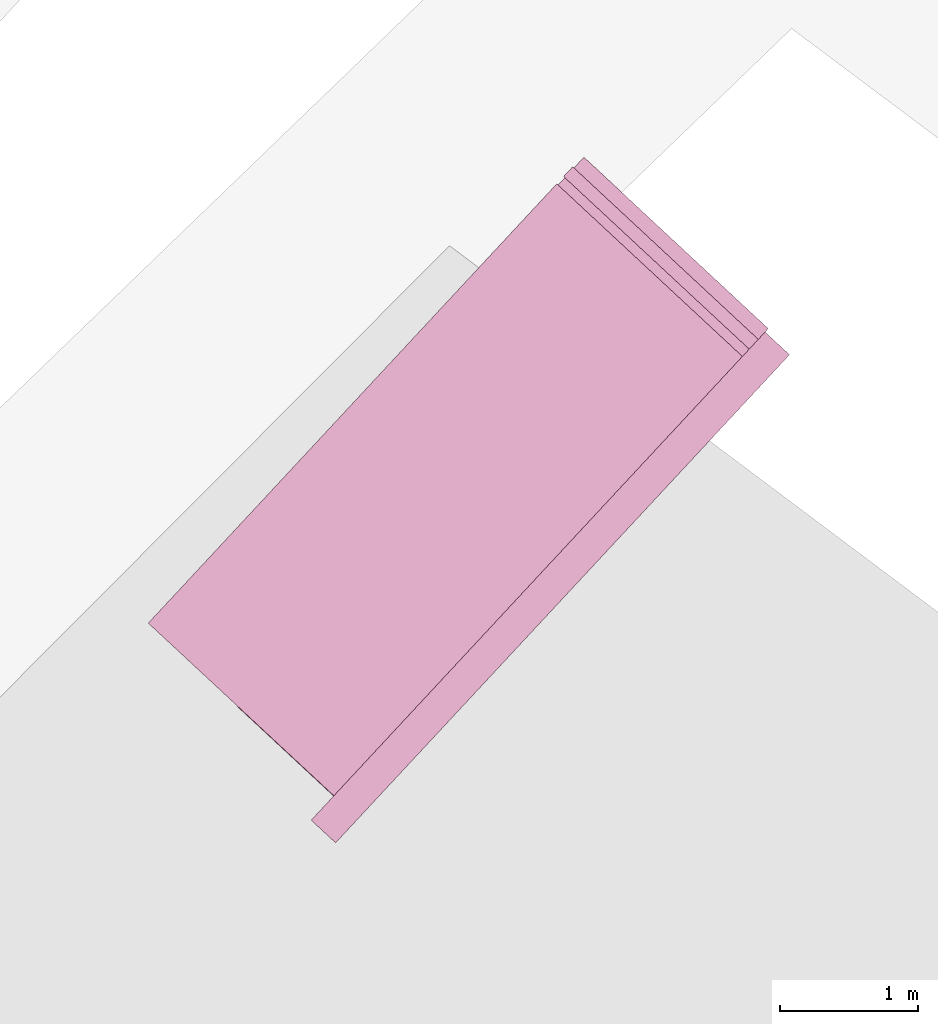
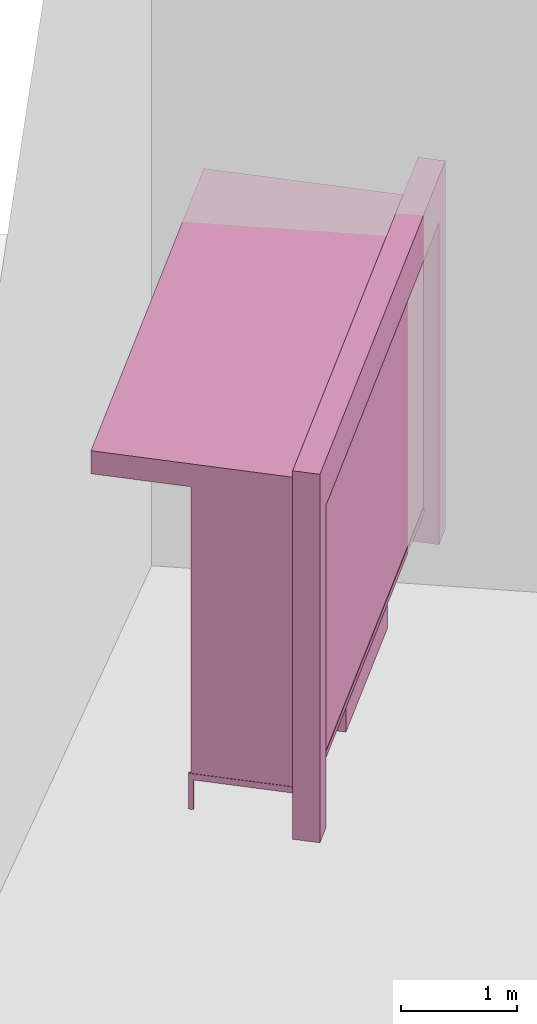
# One storey, part 38 of 200: 1 furnishing.
"""IFC4 building model written with IfcOpenShell, lengths in metres."""

from ifc_helpers import new_model, si_unit, origin_with_axes, place, context, subcontext, project, spatial, triangles, material, element, save


model = new_model("IFC4")

# Units and contexts
model_context = context("Model", 3, precision=1e-05, world=origin_with_axes())
body_context = subcontext(model_context, "Body", "Model", "MODEL_VIEW")
ifc_project = project(units=[si_unit("VOLUMEUNIT", "CUBIC_METRE"), si_unit("LENGTHUNIT", "METRE"), si_unit("AREAUNIT", "SQUARE_METRE")], contexts=[model_context])

# Site, building, storey
site_placement = place(None, origin_with_axes())
site = spatial("IfcSite", under=ifc_project, at=site_placement)
building_placement = place(site_placement, origin_with_axes())
building = spatial("IfcBuilding", under=site, at=building_placement, Name="Building")
storey_placement = place(building_placement, origin_with_axes())
storey = spatial("IfcBuildingStorey", under=building, at=storey_placement, Name="Ground")

# Furnishing
ifc_material = material(Name="busStop")
furnishing_placement = place(storey_placement, origin_with_axes())
element("IfcFurnishingElement", 1, at=furnishing_placement, inside=storey, material=ifc_material, Name="cw_instances_busStop_28", context=body_context, shape_type="Tessellation", body=[
    triangles([(673.4360777471168, -592.662081831775, 3.3828914363241944), (672.0004949629046, -597.2523688925979, 3.3828914363241944), (674.9553393168015, -594.0749006714976, 3.3828914363241944), (670.4812331198481, -595.8395500400575, 3.3828914363241944), (673.4360776765063, -592.6620817661119, 3.6239502858274126), (672.0004948922941, -597.2523688269347, 3.6239502858274126), (670.4812330492376, -595.8395499743943, 3.6239502858274126), (674.9553392461911, -594.0749006058344, 3.6239502858274126), (673.4360777471168, -592.662081831775, 3.3828914363241944), (670.4812330492376, -595.8395499743943, 3.6239502858274126), (670.4812331198481, -595.8395500400575, 3.3828914363241944), (673.4360776765063, -592.6620817661119, 3.6239502858274126), (670.4812331198481, -595.8395500400575, 3.3828914363241944), (672.0004948922941, -597.2523688269347, 3.6239502858274126), (672.0004949629046, -597.2523688925979, 3.3828914363241944), (670.4812330492376, -595.8395499743943, 3.6239502858274126), (672.0004949629046, -597.2523688925979, 3.3828914363241944), (674.9553392461911, -594.0749006058344, 3.6239502858274126), (674.9553393168015, -594.0749006714976, 3.3828914363241944), (672.0004948922941, -597.2523688269347, 3.6239502858274126), (674.9553393168015, -594.0749006714976, 3.3828914363241944), (673.4360776765063, -592.6620817661119, 3.6239502858274126), (673.4360777471168, -592.662081831775, 3.3828914363241944), (674.9553392461911, -594.0749006058344, 3.6239502858274126), (674.7788129463231, -593.9107423906706, 3.8650087335661496), (675.1194970702991, -593.89837418371, 3.8650087335661496), (674.9553389755177, -594.0749003541255, 3.8650087335661496), (674.9429710411044, -593.734216220255, 3.8650087335661496), (674.7788129463231, -593.9107423906706, 3.6239502858274126), (674.9429710411044, -593.734216220255, 3.8650087335661496), (674.7788129463231, -593.9107423906706, 3.8650087335661496), (674.9429710411044, -593.734216220255, 3.6239502858274126), (671.6598104869258, -597.2647364869268, 3.6239502858274126), (671.8363366573413, -597.4288945817083, 3.8650087335661496), (671.8363366573413, -597.4288945817083, 3.6239502858274126), (671.6598104869258, -597.2647364869268, 3.8650087335661496), (672.0004946098525, -597.2523685642819, 3.6239502858274126), (671.8363366573413, -597.4288945817083, 3.8650087335661496), (672.0004946098525, -597.2523685642819, 3.8650087335661496), (671.8363366573413, -597.4288945817083, 3.6239502858274126), (675.1194971997515, -593.8983743040925, 3.6239502858274126), (674.9429710411044, -593.734216220255, 3.8650087335661496), (674.9429710411044, -593.734216220255, 3.6239502858274126), (675.1194970702991, -593.89837418371, 3.8650087335661496), (671.8239685806577, -597.088210600827, 3.8650087335661496), (672.0004946098525, -597.2523685642819, 3.8650087335661496), (671.8239685806577, -597.088210600827, 3.6239502858274126), (671.8239685806577, -597.088210600827, 3.8650087335661496), (675.1194971997515, -593.8983743040925, 3.6239502858274126), (674.9553389755177, -594.0749003541255, 3.8650087335661496), (675.1194970702991, -593.89837418371, 3.8650087335661496), (674.9553389755177, -594.0749003541255, 3.6239502858274126), (671.6598104869258, -597.2647364869268, 3.8650087335661496), (671.8363366573413, -597.4288945817083, 3.8650087335661496), (671.6598104869258, -597.2647364869268, 3.6239502858274126), (671.6598104869258, -597.2647364869268, 3.8650087335661496), (675.1194978352454, -593.8983748950612, 9.481641759365404e-07), (674.9429718766611, -593.7342169972695, 8.999524381770554e-07), (674.9553397404641, -594.0749010654768, 9.481641759365404e-07), (675.1194978352454, -593.8983748950612, 9.481641759365404e-07), (674.9553389755177, -594.0749003541255, 3.6239502858274126), (674.7788136524273, -593.9107430473025, 8.999524381770554e-07), (674.7788129463231, -593.9107423906706, 3.6239502858274126), (674.9553397404641, -594.0749010654768, 9.481641759365404e-07), (674.9429718766611, -593.7342169972695, 8.999524381770554e-07), (674.7788136524273, -593.9107430473025, 8.999524381770554e-07), (671.6598123739182, -597.2647361568869, 8.999524381770554e-07), (671.8363374222876, -597.4288952930594, 9.481641759365404e-07), (671.8239703373731, -597.0882101276922, 8.999524381770554e-07), (671.6598123739182, -597.2647361568869, 8.999524381770554e-07), (671.8239685806577, -597.088210600827, 3.6239502858274126), (672.0004964254098, -597.2523681458665, 9.481641759365404e-07), (672.0004946098525, -597.2523685642819, 3.6239502858274126), (671.8239703373731, -597.0882101276922, 8.999524381770554e-07), (671.8363374222876, -597.4288952930594, 9.481641759365404e-07), (672.0004964254098, -597.2523681458665, 9.481641759365404e-07), (671.1273741282491, -596.4400799329549, 0.3460205594970761), (671.8936109857975, -597.1526314055794, 3.3828914363241944), (671.8936116212913, -597.1526319965482, 0.34602073627344787), (671.1273735515974, -596.4400793967054, 3.3828914363241944), (671.904555476037, -597.1408636048011, 0.34602073627344787), (671.138317406343, -596.4283110049583, 3.3828914363241944), (671.1383179829949, -596.4283115412078, 0.3460205594970761), (671.9045548405431, -597.1408630138324, 3.3828914363241944), (671.1383179829949, -596.4283115412078, 0.3460205594970761), (671.1273735515974, -596.4400793967054, 3.3828914363241944), (671.1273741282491, -596.4400799329549, 0.3460205594970761), (671.138317406343, -596.4283110049583, 3.3828914363241944), (671.9072915081225, -597.1379214333118, 0.31387960990828295), (671.1246382627952, -596.4430219960549, 0.31387941706133193), (671.8908757205321, -597.1555740268166, 0.31387960990828295), (671.1410540503856, -596.4253694025501, 0.31387941706133193), (671.9072915081225, -597.1379214333118, 0.37816187870919205), (671.1246382510268, -596.4430219851109, 0.378161685862241), (671.1410540386172, -596.4253693916062, 0.378161685862241), (671.8908757205321, -597.1555740268166, 0.37816187870919205), (671.9072915081225, -597.1379214333118, 0.31387960990828295), (671.1410540386172, -596.4253693916062, 0.378161685862241), (671.1410540503856, -596.4253694025501, 0.31387941706133193), (671.9072915081225, -597.1379214333118, 0.37816187870919205), (671.1246382627952, -596.4430219960549, 0.31387941706133193), (671.8908757205321, -597.1555740268166, 0.37816187870919205), (671.8908757205321, -597.1555740268166, 0.31387960990828295), (671.1246382510268, -596.4430219851109, 0.378161685862241), (671.1246382510268, -596.4430219851109, 0.378161685862241), (671.1410540503856, -596.4253694025501, 0.31387941706133193), (671.1410540386172, -596.4253693916062, 0.378161685862241), (671.1246382627952, -596.4430219960549, 0.31387941706133193), (671.1223077074548, -596.4130321553358, 0.378161685862241), (671.1433856590356, -596.4553578746113, 0.378161685862241), (671.1109753345332, -596.425218337176, 0.378161685862241), (671.1547180319571, -596.4431716927711, 0.378161685862241), (671.1223078957493, -596.4130323304377, 1.446352132784553e-07), (671.1109753345332, -596.425218337176, 0.378161685862241), (671.1109755228277, -596.4252185122779, 1.446352132784553e-07), (671.1223077074548, -596.4130321553358, 0.378161685862241), (671.1109755228277, -596.4252185122779, 1.446352132784553e-07), (671.1433856590356, -596.4553578746113, 0.378161685862241), (671.1433857414145, -596.4553579512184, 1.60705792531617e-07), (671.1109753345332, -596.425218337176, 0.378161685862241), (671.1433857414145, -596.4553579512184, 1.60705792531617e-07), (671.1547180319571, -596.4431716927711, 0.378161685862241), (671.154718114336, -596.4431717693782, 1.60705792531617e-07), (671.1433856590356, -596.4553578746113, 0.378161685862241), (671.154718114336, -596.4431717693782, 1.60705792531617e-07), (671.1223077074548, -596.4130321553358, 0.378161685862241), (671.1223078957493, -596.4130323304377, 1.446352132784553e-07), (671.1547180319571, -596.4431716927711, 0.378161685862241), (673.8407760131898, -594.822775131854, 1.124940901274063), (672.8587585035449, -596.1041115512872, 1.1249409976975384), (672.7463890911865, -595.9996151550814, 1.124940901274063), (673.9531452843273, -594.9272713967334, 1.1249409976975384), (672.7463892324074, -595.9996152864078, 4.981879568480127e-07), (673.8407760131898, -594.822775131854, 0.9642351730247629), (672.7463890911865, -595.9996151550814, 0.9642351730247629), (673.8407762603263, -594.8227753616751, 4.981879568480127e-07), (672.8587587859865, -596.10411181394, 5.303291153543362e-07), (672.7463890911865, -595.9996151550814, 0.9642351730247629), (672.8587585035449, -596.1041115512872, 0.9642352694482383), (672.7463892324074, -595.9996152864078, 4.981879568480127e-07), (673.9531455667691, -594.9272716593862, 5.303291153543362e-07), (672.8587585035449, -596.1041115512872, 0.9642352694482383), (673.9531452843273, -594.9272713967334, 0.9642352694482383), (672.8587587859865, -596.10411181394, 5.303291153543362e-07), (673.8407762603263, -594.8227753616751, 4.981879568480127e-07), (673.9531452843273, -594.9272713967334, 0.9642352694482383), (673.8407760131898, -594.822775131854, 0.9642351730247629), (673.9531455667691, -594.9272716593862, 5.303291153543362e-07), (672.2756529976427, -595.5618605712764, 1.1249408048505873), (673.370039860804, -594.3850204933296, 0.9642350766012873), (673.3700398372672, -594.3850204714419, 1.1249408048505873), (672.2756530094111, -595.5618605822202, 0.9642350766012873), (672.8587585035449, -596.1041115512872, 1.1249409976975384), (672.7463890911865, -595.9996151550814, 1.124940901274063), (673.9531452843273, -594.9272713967334, 1.1249409976975384), (672.8587585035449, -596.1041115512872, 1.1249409976975384), (673.8407760131898, -594.822775131854, 1.124940901274063), (673.9531452843273, -594.9272713967334, 1.1249409976975384), (673.3700398372672, -594.3850204714419, 1.1249408048505873), (672.2756529976427, -595.5618605712764, 1.1249408048505873), (673.370039860804, -594.3850204933296, 0.9642350766012873), (673.3700398372672, -594.3850204714419, 1.1249408048505873), (672.2756529976427, -595.5618605712764, 1.1249408048505873), (672.2756530094111, -595.5618605822202, 0.9642350766012873), (674.9375242709053, -593.8675855550316, 0.34602073627344787), (671.8054770410532, -597.2356059961706, 3.503420861075804), (671.8054777353891, -597.2356066418588, 0.34602073627344787), (674.9375237766325, -593.8675850953892, 3.503420861075804), (671.8172461389045, -597.2465505075482, 0.34602073627344787), (674.9492921683794, -593.8785289501349, 3.503420861075804), (674.9492926626524, -593.8785294097772, 0.34602073627344787), (671.8172454328003, -597.2465498509164, 3.503420861075804), (674.8844663400779, -593.6555367651829, 0.5810437654796049), (673.6919274325179, -592.5465515390442, 3.219596834180686), (673.6919278561804, -592.5465519330234, 0.5810434762091784), (674.8844658928786, -593.655536349316, 3.219596834180686), (674.9660206159161, -593.7094315675729, 0.4846202738900554), (673.702871710926, -592.5347835412763, 0.5810434762091784), (673.6322624001111, -592.4691192948042, 0.48461995247847034), (674.8954101948235, -593.6437683734358, 0.5810437654796049), (673.7028712872635, -592.5347831472972, 3.219596834180686), (673.63226072495, -592.4691198218337, 3.3160202132761807), (674.8954097476242, -593.6437679575689, 3.219596834180686), (674.9660201334116, -593.7094311188744, 3.3160202132761807), (674.8954101948235, -593.6437683734358, 0.5810437654796049), (673.6919278561804, -592.5465519330234, 0.5810434762091784), (673.702871710926, -592.5347835412763, 0.5810434762091784), (674.8844663400779, -593.6555367651829, 0.5810437654796049), (673.702871710926, -592.5347835412763, 0.5810434762091784), (673.6919274325179, -592.5465515390442, 3.219596834180686), (673.7028712872635, -592.5347831472972, 3.219596834180686), (673.6919278561804, -592.5465519330234, 0.5810434762091784), (673.7028712872635, -592.5347831472972, 3.219596834180686), (674.8844658928786, -593.655536349316, 3.219596834180686), (674.8954097476242, -593.6437679575689, 3.219596834180686), (673.6919274325179, -592.5465515390442, 3.219596834180686), (674.8954097476242, -593.6437679575689, 3.219596834180686), (674.8844663400779, -593.6555367651829, 0.5810437654796049), (674.8954101948235, -593.6437683734358, 0.5810437654796049), (674.8844658928786, -593.655536349316, 3.219596834180686), (673.4220050104377, -592.6952167203161, 3.3160202132761807), (674.9660201334116, -593.7094311188744, 3.3160202132761807), (674.7557642070681, -593.9355278203672, 3.3160202132761807), (673.63226072495, -592.4691198218337, 3.3160202132761807), (673.4220056459316, -592.6952173112849, 0.48461995247847034), (673.63226072495, -592.4691198218337, 3.3160202132761807), (673.4220050104377, -592.6952167203161, 3.3160202132761807), (673.6322624001111, -592.4691192948042, 0.48461995247847034), (674.9660206159161, -593.7094315675729, 0.4846202738900554), (674.7557642070681, -593.9355278203672, 3.3160202132761807), (674.9660201334116, -593.7094311188744, 3.3160202132761807), (674.7557647719514, -593.9355283456728, 0.4846202738900554), (674.6960982291413, -593.8580967816764, 0.5810437654796049), (673.5035594274968, -592.7491116540325, 3.219596834180686), (674.6960976407211, -593.8580962344831, 3.219596834180686), (673.5035598511594, -592.7491120480117, 0.5810434762091784), (674.7557647719514, -593.9355283456728, 0.4846202738900554), (673.4926159964137, -592.7608804397588, 0.5810434762091784), (674.6851543743956, -593.8698651734235, 0.5810437654796049), (673.4220056459316, -592.6952173112849, 0.48461995247847034), (673.4926155727512, -592.7608800457796, 3.219596834180686), (673.4220050104377, -592.6952167203161, 3.3160202132761807), (674.6851537859754, -593.8698646262302, 3.219596834180686), (674.7557642070681, -593.9355278203672, 3.3160202132761807), (674.6851543743956, -593.8698651734235, 0.5810437654796049), (673.5035598511594, -592.7491120480117, 0.5810434762091784), (674.6960982291413, -593.8580967816764, 0.5810437654796049), (673.4926159964137, -592.7608804397588, 0.5810434762091784), (673.4926159964137, -592.7608804397588, 0.5810434762091784), (673.5035594274968, -592.7491116540325, 3.219596834180686), (673.5035598511594, -592.7491120480117, 0.5810434762091784), (673.4926155727512, -592.7608800457796, 3.219596834180686), (673.4926155727512, -592.7608800457796, 3.219596834180686), (674.6960976407211, -593.8580962344831, 3.219596834180686), (673.5035594274968, -592.7491116540325, 3.219596834180686), (674.6851537859754, -593.8698646262302, 3.219596834180686), (674.6851537859754, -593.8698646262302, 3.219596834180686), (674.6960982291413, -593.8580967816764, 0.5810437654796049), (674.6960976407211, -593.8580962344831, 3.219596834180686), (674.6851543743956, -593.8698651734235, 0.5810437654796049), (673.5509871877508, -592.5385148305454, 3.3290117659679117), (674.8280607119185, -593.8577847433567, 3.3290117659679117), (673.4853250989441, -592.6091240630292, 3.3290117659679117), (674.8937238403923, -593.7871743928745, 3.3290117659679117), (673.5509888530173, -592.5385140309686, 0.0), (673.4853250989441, -592.6091240630292, 3.3290117659679117), (673.4853255932171, -592.6091245226716, 0.0), (673.5509871877508, -592.5385148305454, 3.3290117659679117), (673.4853255932171, -592.6091245226716, 0.0), (674.8280607119185, -593.8577847433567, 3.3290117659679117), (674.8280612650335, -593.8577852577183, 5.142585361011745e-07), (673.4853250989441, -592.6091240630292, 3.3290117659679117), (674.8280612650335, -593.8577852577183, 5.142585361011745e-07), (674.8937238403923, -593.7871743928745, 3.3290117659679117), (674.8937243935073, -593.7871749072361, 5.142585361011745e-07), (674.8280607119185, -593.8577847433567, 3.3290117659679117), (674.8937243935073, -593.7871749072361, 5.142585361011745e-07), (673.5509871877508, -592.5385148305454, 3.3290117659679117), (673.5509888530173, -592.5385140309686, 0.0), (674.8937238403923, -593.7871743928745, 3.3290117659679117), (674.9345821700265, -593.8648495886092, 0.31387960990828295), (671.8879515877567, -597.176417786268, 0.31387960990828295), (674.9522348341417, -593.8812654418628, 0.31387960990828295), (671.8702990060203, -597.1600020096214, 0.31387960990828295), (674.9345821700265, -593.8648495886092, 0.37816187870919205), (671.8879515877567, -597.176417786268, 0.37816187870919205), (671.8702990060203, -597.1600020096214, 0.37816187870919205), (674.9522348341417, -593.8812654418628, 0.37816187870919205), (674.9345821700265, -593.8648495886092, 0.31387960990828295), (671.8702990060203, -597.1600020096214, 0.37816187870919205), (671.8702990060203, -597.1600020096214, 0.31387960990828295), (674.9345821700265, -593.8648495886092, 0.37816187870919205), (671.8879515877567, -597.176417786268, 0.31387960990828295), (674.9522348341417, -593.8812654418628, 0.37816187870919205), (674.9522348341417, -593.8812654418628, 0.31387960990828295), (671.8879515877567, -597.176417786268, 0.37816187870919205), (673.8430397132043, -595.0443359024995, 1.5291761377398037), (672.9675299528266, -595.9858077358602, 2.8148223012163682), (673.8430394307627, -595.0443356398467, 2.8148223012163682), (672.9675302352682, -595.985807998513, 1.5291761377398037), (673.8112598863173, -595.0586737127231, 1.5613174569519195), (672.9795256223538, -595.9530719194292, 2.782681174851203), (672.9795260342479, -595.9530723024645, 1.5613174569519195), (673.8112597450964, -595.0586735813968, 2.782681174851203), (673.8430397132043, -595.0443359024995, 1.5291761377398037), (672.9458697589571, -595.9656651351918, 1.5291761377398037), (672.9675302352682, -595.985807998513, 1.5291761377398037), (673.821379378114, -595.0241931705046, 1.5291761377398037), (672.9675302352682, -595.985807998513, 1.5291761377398037), (672.9458696295046, -595.9656650148092, 2.8148223012163682), (672.9675299528266, -595.9858077358602, 2.8148223012163682), (672.9458697589571, -595.9656651351918, 1.5291761377398037), (672.9675299528266, -595.9858077358602, 2.8148223012163682), (673.8213790956723, -595.0241929078519, 2.8148223012163682), (673.8430394307627, -595.0443356398467, 2.8148223012163682), (672.9458696295046, -595.9656650148092, 2.8148223012163682), (673.8430394307627, -595.0443356398467, 2.8148223012163682), (673.821379378114, -595.0241931705046, 1.5291761377398037), (673.8430397132043, -595.0443359024995, 1.5291761377398037), (673.8213790956723, -595.0241929078519, 2.8148223012163682), (672.7119445584838, -596.2606501303977, 1.5291761377398037), (672.1647506434616, -596.8490698514743, 2.8148223012163682), (672.7119440691581, -596.2606498070289, 2.8148223012163682), (672.1647509259033, -596.849070114127, 1.5291761377398037), (672.6801647743227, -596.2749881778634, 1.5613174569519195), (672.1767464919884, -596.8163342673381, 2.782681174851203), (672.1767467038197, -596.8163344643277, 1.5613174569519195), (672.6801643624286, -596.2749877948281, 2.782681174851203), (672.7119445584838, -596.2606501303977, 1.5291761377398037), (672.1430906025814, -596.8289273930761, 1.5291761377398037), (672.1647509259033, -596.849070114127, 1.5291761377398037), (672.6902840821726, -596.2405072670765, 1.5291761377398037), (672.1647509259033, -596.849070114127, 1.5291761377398037), (672.1430903201397, -596.8289271304233, 2.8148223012163682), (672.1647506434616, -596.8490698514743, 2.8148223012163682), (672.1430906025814, -596.8289273930761, 1.5291761377398037), (672.1647506434616, -596.8490698514743, 2.8148223012163682), (672.6902837458362, -596.240507085978, 2.8148223012163682), (672.7119440691581, -596.2606498070289, 2.8148223012163682), (672.1430903201397, -596.8289271304233, 2.8148223012163682), (672.7119440691581, -596.2606498070289, 2.8148223012163682), (672.6902840821726, -596.2405072670765, 1.5291761377398037), (672.7119445584838, -596.2606501303977, 1.5291761377398037), (672.6902837458362, -596.240507085978, 2.8148223012163682), (673.821379378114, -595.0241931705046, 1.5291761377398037), (672.9677575718904, -595.9421283820558, 1.5613174569519195), (672.9458697589571, -595.9656651351918, 1.5291761377398037), (673.7994916357911, -595.0477299893039, 1.5613174569519195), (672.9677573718276, -595.94212819601, 2.782681174851203), (672.9458696295046, -595.9656650148092, 2.8148223012163682), (673.7994913533495, -595.0477297266511, 2.782681174851203), (673.8213790956723, -595.0241929078519, 2.8148223012163682), (672.6902840821726, -596.2405072670765, 1.5291761377398037), (672.1649783120727, -596.805390609582, 1.5613174569519195), (672.1430906025814, -596.8289273930761, 1.5291761377398037), (672.6683962413549, -596.2640441917914, 1.5613174569519195), (672.164978029631, -596.8053903469292, 2.782681174851203), (672.1430903201397, -596.8289271304233, 2.8148223012163682), (672.6683959706817, -596.2640439400825, 2.782681174851203), (672.6902837458362, -596.240507085978, 2.8148223012163682), (673.7994916357911, -595.0477299893039, 1.5613174569519195), (672.9795260342479, -595.9530723024645, 1.5613174569519195), (672.9677575718904, -595.9421283820558, 1.5613174569519195), (673.8112598863173, -595.0586737127231, 1.5613174569519195), (672.9677575718904, -595.9421283820558, 1.5613174569519195), (672.9795256223538, -595.9530719194292, 2.782681174851203), (672.9677573718276, -595.94212819601, 2.782681174851203), (672.9795260342479, -595.9530723024645, 1.5613174569519195), (672.9677573718276, -595.94212819601, 2.782681174851203), (673.8112597450964, -595.0586735813968, 2.782681174851203), (673.7994913533495, -595.0477297266511, 2.782681174851203), (672.9795256223538, -595.9530719194292, 2.782681174851203), (673.7994913533495, -595.0477297266511, 2.782681174851203), (673.8112598863173, -595.0586737127231, 1.5613174569519195), (673.7994916357911, -595.0477299893039, 1.5613174569519195), (673.8112597450964, -595.0586735813968, 2.782681174851203), (672.6683962413549, -596.2640441917914, 1.5613174569519195), (672.1767467038197, -596.8163344643277, 1.5613174569519195), (672.1649783120727, -596.805390609582, 1.5613174569519195), (672.6801647743227, -596.2749881778634, 1.5613174569519195), (672.1649783120727, -596.805390609582, 1.5613174569519195), (672.1767464919884, -596.8163342673381, 2.782681174851203), (672.164978029631, -596.8053903469292, 2.782681174851203), (672.1767467038197, -596.8163344643277, 1.5613174569519195), (672.164978029631, -596.8053903469292, 2.782681174851203), (672.6801643624286, -596.2749877948281, 2.782681174851203), (672.6683959706817, -596.2640439400825, 2.782681174851203), (672.1767464919884, -596.8163342673381, 2.782681174851203), (672.6683959706817, -596.2640439400825, 2.782681174851203), (672.6801647743227, -596.2749881778634, 1.5613174569519195), (672.6683962413549, -596.2640441917914, 1.5613174569519195), (672.6801643624286, -596.2749877948281, 2.782681174851203)], [[1, 3, 2], [2, 4, 1], [5, 7, 6], [6, 8, 5], [9, 11, 10], [10, 12, 9], [13, 15, 14], [14, 16, 13], [17, 19, 18], [18, 20, 17], [21, 23, 22], [22, 24, 21], [25, 27, 26], [26, 28, 25], [29, 31, 30], [30, 32, 29], [33, 35, 34], [34, 36, 33], [37, 39, 38], [38, 40, 37], [41, 43, 42], [42, 44, 41], [45, 46, 27], [27, 25, 45], [47, 48, 31], [31, 29, 47], [49, 51, 50], [50, 52, 49], [52, 50, 39], [39, 37, 52], [53, 54, 46], [46, 45, 53], [55, 56, 48], [48, 47, 55], [43, 41, 57], [57, 58, 43], [49, 52, 59], [59, 60, 49], [61, 63, 62], [62, 64, 61], [29, 32, 65], [65, 66, 29], [35, 33, 67], [67, 68, 35], [55, 47, 69], [69, 70, 55], [71, 73, 72], [72, 74, 71], [37, 40, 75], [75, 76, 37], [77, 79, 78], [78, 80, 77], [81, 83, 82], [82, 84, 81], [85, 87, 86], [86, 88, 85], [89, 91, 90], [90, 92, 89], [93, 95, 94], [94, 96, 93], [97, 99, 98], [98, 100, 97], [101, 103, 102], [102, 104, 101], [105, 107, 106], [106, 108, 105], [109, 111, 110], [110, 112, 109], [113, 115, 114], [114, 116, 113], [117, 119, 118], [118, 120, 117], [121, 123, 122], [122, 124, 121], [125, 127, 126], [126, 128, 125], [129, 131, 130], [130, 132, 129], [133, 135, 134], [134, 136, 133], [137, 139, 138], [138, 140, 137], [141, 143, 142], [142, 144, 141], [145, 147, 146], [146, 148, 145], [149, 151, 150], [150, 152, 149], [153, 154, 138], [138, 139, 153], [155, 156, 142], [142, 143, 155], [157, 158, 146], [146, 147, 157], [131, 129, 159], [159, 160, 131], [157, 147, 161], [161, 162, 157], [138, 154, 163], [163, 164, 138], [165, 167, 166], [166, 168, 165], [169, 171, 170], [170, 172, 169], [173, 175, 174], [174, 176, 173], [177, 179, 178], [178, 180, 177], [179, 182, 181], [181, 178, 179], [182, 184, 183], [183, 181, 182], [184, 177, 180], [180, 183, 184], [185, 187, 186], [186, 188, 185], [189, 191, 190], [190, 192, 189], [193, 195, 194], [194, 196, 193], [197, 199, 198], [198, 200, 197], [201, 203, 202], [202, 204, 201], [205, 207, 206], [206, 208, 205], [209, 211, 210], [210, 212, 209], [213, 215, 214], [214, 216, 213], [217, 219, 218], [218, 220, 217], [220, 218, 221], [221, 222, 220], [222, 221, 223], [223, 224, 222], [224, 223, 219], [219, 217, 224], [225, 227, 226], [226, 228, 225], [229, 231, 230], [230, 232, 229], [233, 235, 234], [234, 236, 233], [237, 239, 238], [238, 240, 237], [241, 243, 242], [242, 244, 241], [245, 247, 246], [246, 248, 245], [249, 251, 250], [250, 252, 249], [253, 255, 254], [254, 256, 253], [257, 259, 258], [258, 260, 257], [261, 263, 262], [262, 264, 261], [265, 267, 266], [266, 268, 265], [269, 271, 270], [270, 272, 269], [273, 275, 274], [274, 276, 273], [277, 279, 278], [278, 280, 277], [281, 283, 282], [282, 284, 281], [285, 287, 286], [286, 288, 285], [289, 291, 290], [290, 292, 289], [293, 295, 294], [294, 296, 293], [297, 299, 298], [298, 300, 297], [301, 303, 302], [302, 304, 301], [305, 307, 306], [306, 308, 305], [309, 311, 310], [310, 312, 309], [313, 315, 314], [314, 316, 313], [317, 319, 318], [318, 320, 317], [321, 323, 322], [322, 324, 321], [325, 327, 326], [326, 328, 325], [327, 330, 329], [329, 326, 327], [330, 332, 331], [331, 329, 330], [332, 325, 328], [328, 331, 332], [333, 335, 334], [334, 336, 333], [335, 338, 337], [337, 334, 335], [338, 340, 339], [339, 337, 338], [340, 333, 336], [336, 339, 340], [341, 343, 342], [342, 344, 341], [345, 347, 346], [346, 348, 345], [349, 351, 350], [350, 352, 349], [353, 355, 354], [354, 356, 353], [357, 359, 358], [358, 360, 357], [361, 363, 362], [362, 364, 361], [365, 367, 366], [366, 368, 365], [369, 371, 370], [370, 372, 369]], closed=True),
])

save(model, "model.ifc")
